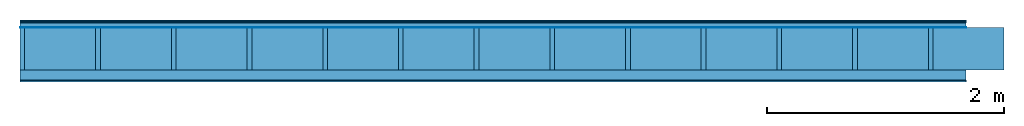
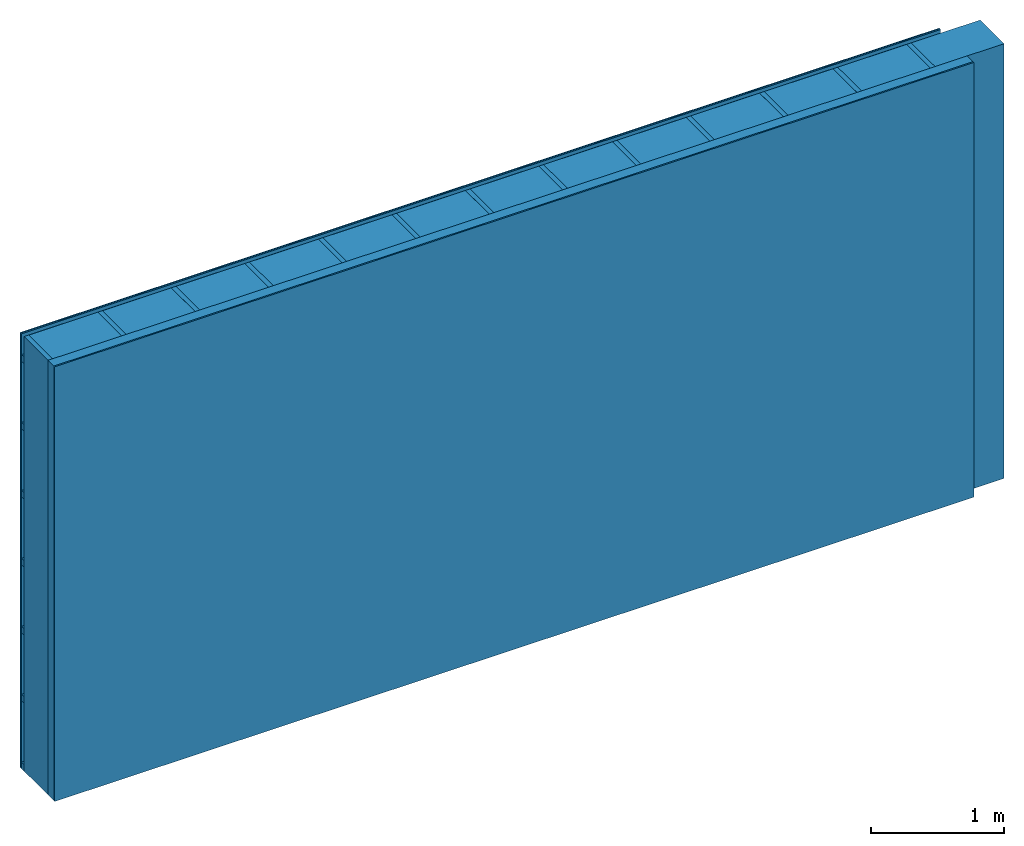
# One storey: 5 plates, 3 members, 1 element without a shape of its own.
"""IFC4 building model written with IfcOpenShell, lengths in metres."""

from ifc_helpers import new_model, si_unit, derived_unit, direction, frame, frame_2d, origin, origin_with_axes, place, context, project, spatial, rectangle, extrude, material, layer, layer_set, type_object, element, aggregate, save


model = new_model("IFC4")

# Units and contexts
plan_context = context("Plan", 3, precision=1e-05, world=origin(), true_north=direction((0.0, 1.0)))
model_context = context("Model", 3, precision=1e-05, world=origin(), true_north=direction((0.0, 1.0)))
ifc_project = project(units=[si_unit("LENGTHUNIT", "METRE"), derived_unit("SOUNDPRESSUREUNIT", [(si_unit("PRESSUREUNIT", "PASCAL", prefix="MICRO"), 0)]), si_unit("ENERGYUNIT", "JOULE", prefix="MEGA"), si_unit("MASSUNIT", "GRAM", prefix="KILO"), derived_unit("THERMALTRANSMITTANCEUNIT", [(si_unit("POWERUNIT", "WATT"), 1), (si_unit("AREAUNIT", "SQUARE_METRE"), -1), (si_unit("THERMODYNAMICTEMPERATUREUNIT", "KELVIN"), -1)]), derived_unit("AREADENSITYUNIT", [(si_unit("MASSUNIT", "GRAM", prefix="KILO"), 1), (si_unit("AREAUNIT", "SQUARE_METRE"), -1)]), derived_unit("USERDEFINED", [(si_unit("ENERGYUNIT", "JOULE", prefix="MEGA"), 1), (si_unit("AREAUNIT", "SQUARE_METRE"), -1)])], contexts=[plan_context, model_context])

# Site, building, storey
site = spatial("IfcSite", under=ifc_project)
building_placement = place(None, origin())
building = spatial("IfcBuilding", under=site, at=building_placement)
storey_placement = place(building_placement, origin())
storey = spatial("IfcBuildingStorey", under=building, at=storey_placement)

# Wall, members, plates
ifc_material_1 = material(Category="04.011")
ifc_layer_1 = layer(ifc_material_1, 0.01, Name="Surface 1")
ifc_material_2 = material(Name="mineral, cement-based building board", Category="03.003")
ifc_layer_2 = layer(ifc_material_2, 0.013, Name="Cover 1st layer")
ifc_layer_3 = layer(None, 0.04, Name="Battens / profiles (ventilation)")
ifc_material_3 = material(Name="Vapor-permeable water barrier", Category="09.006")
ifc_layer_4 = layer(ifc_material_3, 0.0005, Name="outside 1st layer")
ifc_material_4 = material(Name="of the art")
ifc_layer_5 = layer(ifc_material_4, 0.0, Name="Bond")
ifc_layer_6 = layer(None, 0.36, Name="Support")
ifc_layer_7 = layer(ifc_material_4, 0.0, Name="Bond")
ifc_material_5 = material(Name="Solid timber panel")
ifc_layer_8 = layer(ifc_material_5, 0.087, Name="1st layer")
ifc_material_6 = material(Name="Plasterboard type A", Category="03.008")
ifc_layer_9 = layer(ifc_material_6, 0.0125, Name="Covering 1st layer")
ifc_material_7 = material(Name="joints", Category="04.017")
ifc_layer_10 = layer(ifc_material_7, 0.0, Name="Surface")
ifc_layer_set = layer_set([ifc_layer_1, ifc_layer_2, ifc_layer_3, ifc_layer_4, ifc_layer_5, ifc_layer_6, ifc_layer_7, ifc_layer_8, ifc_layer_9, ifc_layer_10])
wall_type = type_object("IfcWallType", Name="D1008", PredefinedType="NOTDEFINED", material=ifc_layer_set)
wall_placement = place(None, frame((0.0, 0.0, 0.0), z_axis=(0.0, -1.0, 0.0), x_axis=(1.0, 0.0, 0.0)))
wall = element("IfcWall", 1, at=wall_placement, inside=storey, type_object=wall_type, material=ifc_layer_set, Name="Wall #1")
ifc_material_8 = material()
member_1_placement = place(wall_placement, origin())
member_1 = element("IfcMember", 2, at=member_1_placement, material=ifc_material_8, Name="Battens / profiles (ventilation)", context=plan_context, shape_type="SweptSolid", body=[
    extrude(rectangle(XDim=0.06, YDim=0.04, at=frame_2d((0.03, 0.02), x_axis=(1.0, 0.0))), frame((0.0, 0.0, 0.023), z_axis=(1.0, 0.0, 0.0), x_axis=(0.0, 1.0, 0.0)), (0.0, 0.0, 1.0), 8.0),
    extrude(rectangle(XDim=0.06, YDim=0.04, at=frame_2d((0.03, 0.02), x_axis=(1.0, 0.0))), frame((0.0, 0.625, 0.023), z_axis=(1.0, 0.0, 0.0), x_axis=(0.0, 1.0, 0.0)), (0.0, 0.0, 1.0), 8.0),
    extrude(rectangle(XDim=0.06, YDim=0.04, at=frame_2d((0.03, 0.02), x_axis=(1.0, 0.0))), frame((0.0, 1.25, 0.023), z_axis=(1.0, 0.0, 0.0), x_axis=(0.0, 1.0, 0.0)), (0.0, 0.0, 1.0), 8.0),
    extrude(rectangle(XDim=0.06, YDim=0.04, at=frame_2d((0.03, 0.02), x_axis=(1.0, 0.0))), frame((0.0, 1.875, 0.023), z_axis=(1.0, 0.0, 0.0), x_axis=(0.0, 1.0, 0.0)), (0.0, 0.0, 1.0), 8.0),
    extrude(rectangle(XDim=0.06, YDim=0.04, at=frame_2d((0.03, 0.02), x_axis=(1.0, 0.0))), frame((0.0, 2.5, 0.023), z_axis=(1.0, 0.0, 0.0), x_axis=(0.0, 1.0, 0.0)), (0.0, 0.0, 1.0), 8.0),
    extrude(rectangle(XDim=0.06, YDim=0.04, at=frame_2d((0.03, 0.02), x_axis=(1.0, 0.0))), frame((0.0, 3.125, 0.023), z_axis=(1.0, 0.0, 0.0), x_axis=(0.0, 1.0, 0.0)), (0.0, 0.0, 1.0), 8.0),
    extrude(rectangle(XDim=0.06, YDim=0.04, at=frame_2d((0.03, 0.02), x_axis=(1.0, 0.0))), frame((0.0, 3.75, 0.023), z_axis=(1.0, 0.0, 0.0), x_axis=(0.0, 1.0, 0.0)), (0.0, 0.0, 1.0), 8.0),
])
ifc_material_9 = material()
member_2_placement = place(wall_placement, origin())
member_2 = element("IfcMember", 3, at=member_2_placement, material=ifc_material_9, Name="Support", context=plan_context, shape_type="SweptSolid", body=[
    extrude(rectangle(XDim=0.04, YDim=0.36, at=frame_2d((0.02, 0.18), x_axis=(1.0, 0.0))), frame((0.0, 4.0, 0.0635), z_axis=(0.0, -1.0, 0.0), x_axis=(1.0, 0.0, 0.0)), (0.0, 0.0, 1.0), 4.0),
    extrude(rectangle(XDim=0.04, YDim=0.36, at=frame_2d((0.02, 0.18), x_axis=(1.0, 0.0))), frame((0.64, 4.0, 0.0635), z_axis=(0.0, -1.0, 0.0), x_axis=(1.0, 0.0, 0.0)), (0.0, 0.0, 1.0), 4.0),
    extrude(rectangle(XDim=0.04, YDim=0.36, at=frame_2d((0.02, 0.18), x_axis=(1.0, 0.0))), frame((1.28, 4.0, 0.0635), z_axis=(0.0, -1.0, 0.0), x_axis=(1.0, 0.0, 0.0)), (0.0, 0.0, 1.0), 4.0),
    extrude(rectangle(XDim=0.04, YDim=0.36, at=frame_2d((0.02, 0.18), x_axis=(1.0, 0.0))), frame((1.92, 4.0, 0.0635), z_axis=(0.0, -1.0, 0.0), x_axis=(1.0, 0.0, 0.0)), (0.0, 0.0, 1.0), 4.0),
    extrude(rectangle(XDim=0.04, YDim=0.36, at=frame_2d((0.02, 0.18), x_axis=(1.0, 0.0))), frame((2.56, 4.0, 0.0635), z_axis=(0.0, -1.0, 0.0), x_axis=(1.0, 0.0, 0.0)), (0.0, 0.0, 1.0), 4.0),
    extrude(rectangle(XDim=0.04, YDim=0.36, at=frame_2d((0.02, 0.18), x_axis=(1.0, 0.0))), frame((3.2, 4.0, 0.0635), z_axis=(0.0, -1.0, 0.0), x_axis=(1.0, 0.0, 0.0)), (0.0, 0.0, 1.0), 4.0),
    extrude(rectangle(XDim=0.04, YDim=0.36, at=frame_2d((0.02, 0.18), x_axis=(1.0, 0.0))), frame((3.84, 4.0, 0.0635), z_axis=(0.0, -1.0, 0.0), x_axis=(1.0, 0.0, 0.0)), (0.0, 0.0, 1.0), 4.0),
    extrude(rectangle(XDim=0.04, YDim=0.36, at=frame_2d((0.02, 0.18), x_axis=(1.0, 0.0))), frame((4.48, 4.0, 0.0635), z_axis=(0.0, -1.0, 0.0), x_axis=(1.0, 0.0, 0.0)), (0.0, 0.0, 1.0), 4.0),
    extrude(rectangle(XDim=0.04, YDim=0.36, at=frame_2d((0.02, 0.18), x_axis=(1.0, 0.0))), frame((5.12, 4.0, 0.0635), z_axis=(0.0, -1.0, 0.0), x_axis=(1.0, 0.0, 0.0)), (0.0, 0.0, 1.0), 4.0),
    extrude(rectangle(XDim=0.04, YDim=0.36, at=frame_2d((0.02, 0.18), x_axis=(1.0, 0.0))), frame((5.76, 4.0, 0.0635), z_axis=(0.0, -1.0, 0.0), x_axis=(1.0, 0.0, 0.0)), (0.0, 0.0, 1.0), 4.0),
    extrude(rectangle(XDim=0.04, YDim=0.36, at=frame_2d((0.02, 0.18), x_axis=(1.0, 0.0))), frame((6.4, 4.0, 0.0635), z_axis=(0.0, -1.0, 0.0), x_axis=(1.0, 0.0, 0.0)), (0.0, 0.0, 1.0), 4.0),
    extrude(rectangle(XDim=0.04, YDim=0.36, at=frame_2d((0.02, 0.18), x_axis=(1.0, 0.0))), frame((7.04, 4.0, 0.0635), z_axis=(0.0, -1.0, 0.0), x_axis=(1.0, 0.0, 0.0)), (0.0, 0.0, 1.0), 4.0),
    extrude(rectangle(XDim=0.04, YDim=0.36, at=frame_2d((0.02, 0.18), x_axis=(1.0, 0.0))), frame((7.68, 4.0, 0.0635), z_axis=(0.0, -1.0, 0.0), x_axis=(1.0, 0.0, 0.0)), (0.0, 0.0, 1.0), 4.0),
])
ifc_material_10 = material(Name="Mineral wool")
member_3_placement = place(wall_placement, origin())
member_3 = element("IfcMember", 4, at=member_3_placement, material=ifc_material_10, Name="Cavity", context=plan_context, shape_type="SweptSolid", body=[
    extrude(rectangle(XDim=0.6, YDim=0.36, at=frame_2d((0.3, 0.18), x_axis=(1.0, 0.0))), frame((0.04, 4.0, 0.0635), z_axis=(0.0, -1.0, 0.0), x_axis=(1.0, 0.0, 0.0)), (0.0, 0.0, 1.0), 4.0),
    extrude(rectangle(XDim=0.6, YDim=0.36, at=frame_2d((0.3, 0.18), x_axis=(1.0, 0.0))), frame((0.68, 4.0, 0.0635), z_axis=(0.0, -1.0, 0.0), x_axis=(1.0, 0.0, 0.0)), (0.0, 0.0, 1.0), 4.0),
    extrude(rectangle(XDim=0.6, YDim=0.36, at=frame_2d((0.3, 0.18), x_axis=(1.0, 0.0))), frame((1.32, 4.0, 0.0635), z_axis=(0.0, -1.0, 0.0), x_axis=(1.0, 0.0, 0.0)), (0.0, 0.0, 1.0), 4.0),
    extrude(rectangle(XDim=0.6, YDim=0.36, at=frame_2d((0.3, 0.18), x_axis=(1.0, 0.0))), frame((1.96, 4.0, 0.0635), z_axis=(0.0, -1.0, 0.0), x_axis=(1.0, 0.0, 0.0)), (0.0, 0.0, 1.0), 4.0),
    extrude(rectangle(XDim=0.6, YDim=0.36, at=frame_2d((0.3, 0.18), x_axis=(1.0, 0.0))), frame((2.6, 4.0, 0.0635), z_axis=(0.0, -1.0, 0.0), x_axis=(1.0, 0.0, 0.0)), (0.0, 0.0, 1.0), 4.0),
    extrude(rectangle(XDim=0.6, YDim=0.36, at=frame_2d((0.3, 0.18), x_axis=(1.0, 0.0))), frame((3.24, 4.0, 0.0635), z_axis=(0.0, -1.0, 0.0), x_axis=(1.0, 0.0, 0.0)), (0.0, 0.0, 1.0), 4.0),
    extrude(rectangle(XDim=0.6, YDim=0.36, at=frame_2d((0.3, 0.18), x_axis=(1.0, 0.0))), frame((3.88, 4.0, 0.0635), z_axis=(0.0, -1.0, 0.0), x_axis=(1.0, 0.0, 0.0)), (0.0, 0.0, 1.0), 4.0),
    extrude(rectangle(XDim=0.6, YDim=0.36, at=frame_2d((0.3, 0.18), x_axis=(1.0, 0.0))), frame((4.52, 4.0, 0.0635), z_axis=(0.0, -1.0, 0.0), x_axis=(1.0, 0.0, 0.0)), (0.0, 0.0, 1.0), 4.0),
    extrude(rectangle(XDim=0.6, YDim=0.36, at=frame_2d((0.3, 0.18), x_axis=(1.0, 0.0))), frame((5.16, 4.0, 0.0635), z_axis=(0.0, -1.0, 0.0), x_axis=(1.0, 0.0, 0.0)), (0.0, 0.0, 1.0), 4.0),
    extrude(rectangle(XDim=0.6, YDim=0.36, at=frame_2d((0.3, 0.18), x_axis=(1.0, 0.0))), frame((5.8, 4.0, 0.0635), z_axis=(0.0, -1.0, 0.0), x_axis=(1.0, 0.0, 0.0)), (0.0, 0.0, 1.0), 4.0),
    extrude(rectangle(XDim=0.6, YDim=0.36, at=frame_2d((0.3, 0.18), x_axis=(1.0, 0.0))), frame((6.44, 4.0, 0.0635), z_axis=(0.0, -1.0, 0.0), x_axis=(1.0, 0.0, 0.0)), (0.0, 0.0, 1.0), 4.0),
    extrude(rectangle(XDim=0.6, YDim=0.36, at=frame_2d((0.3, 0.18), x_axis=(1.0, 0.0))), frame((7.08, 4.0, 0.0635), z_axis=(0.0, -1.0, 0.0), x_axis=(1.0, 0.0, 0.0)), (0.0, 0.0, 1.0), 4.0),
    extrude(rectangle(XDim=0.6, YDim=0.36, at=frame_2d((0.3, 0.18), x_axis=(1.0, 0.0))), frame((7.72, 4.0, 0.0635), z_axis=(0.0, -1.0, 0.0), x_axis=(1.0, 0.0, 0.0)), (0.0, 0.0, 1.0), 4.0),
])
plate_1_placement = place(wall_placement, origin())
plate_1 = element("IfcPlate", 5, at=plate_1_placement, material=ifc_material_1, Name="Surface 1", context=plan_context, shape_type="SweptSolid", body=[
    extrude(rectangle(XDim=8.0, YDim=4.0, at=frame_2d((4.0, 2.0), x_axis=(1.0, 0.0))), origin_with_axes(), (0.0, 0.0, 1.0), 0.01),
])
plate_2_placement = place(wall_placement, origin())
plate_2 = element("IfcPlate", 6, at=plate_2_placement, material=ifc_material_2, Name="Cover 1st layer", context=plan_context, shape_type="SweptSolid", body=[
    extrude(rectangle(XDim=8.0, YDim=4.0, at=frame_2d((4.0, 2.0), x_axis=(1.0, 0.0))), frame((0.0, 0.0, 0.01), z_axis=(0.0, 0.0, 1.0), x_axis=(1.0, 0.0, 0.0)), (0.0, 0.0, 1.0), 0.013),
])
plate_3_placement = place(wall_placement, origin())
plate_3 = element("IfcPlate", 7, at=plate_3_placement, material=ifc_material_3, Name="outside 1st layer", context=plan_context, shape_type="SweptSolid", body=[
    extrude(rectangle(XDim=8.0, YDim=4.0, at=frame_2d((4.0, 2.0), x_axis=(1.0, 0.0))), frame((0.0, 0.0, 0.063), z_axis=(0.0, 0.0, 1.0), x_axis=(1.0, 0.0, 0.0)), (0.0, 0.0, 1.0), 0.0005),
])
plate_4_placement = place(wall_placement, origin())
plate_4 = element("IfcPlate", 8, at=plate_4_placement, material=ifc_material_5, Name="1st layer", context=plan_context, shape_type="SweptSolid", body=[
    extrude(rectangle(XDim=8.0, YDim=4.0, at=frame_2d((4.0, 2.0), x_axis=(1.0, 0.0))), frame((0.0, 0.0, 0.4235), z_axis=(0.0, 0.0, 1.0), x_axis=(1.0, 0.0, 0.0)), (0.0, 0.0, 1.0), 0.087),
])
plate_5_placement = place(wall_placement, origin())
plate_5 = element("IfcPlate", 9, at=plate_5_placement, material=ifc_material_6, Name="Covering 1st layer", context=plan_context, shape_type="SweptSolid", body=[
    extrude(rectangle(XDim=8.0, YDim=4.0, at=frame_2d((4.0, 2.0), x_axis=(1.0, 0.0))), frame((0.0, 0.0, 0.5105), z_axis=(0.0, 0.0, 1.0), x_axis=(1.0, 0.0, 0.0)), (0.0, 0.0, 1.0), 0.0125),
])
aggregate(wall, [plate_1, plate_2, member_1, plate_3, member_2, member_3, plate_4, plate_5])

save(model, "model.ifc")
